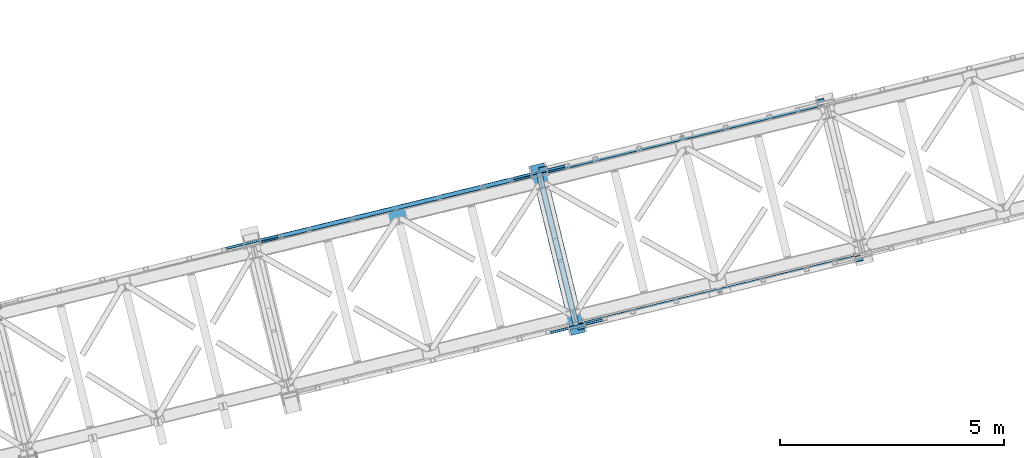
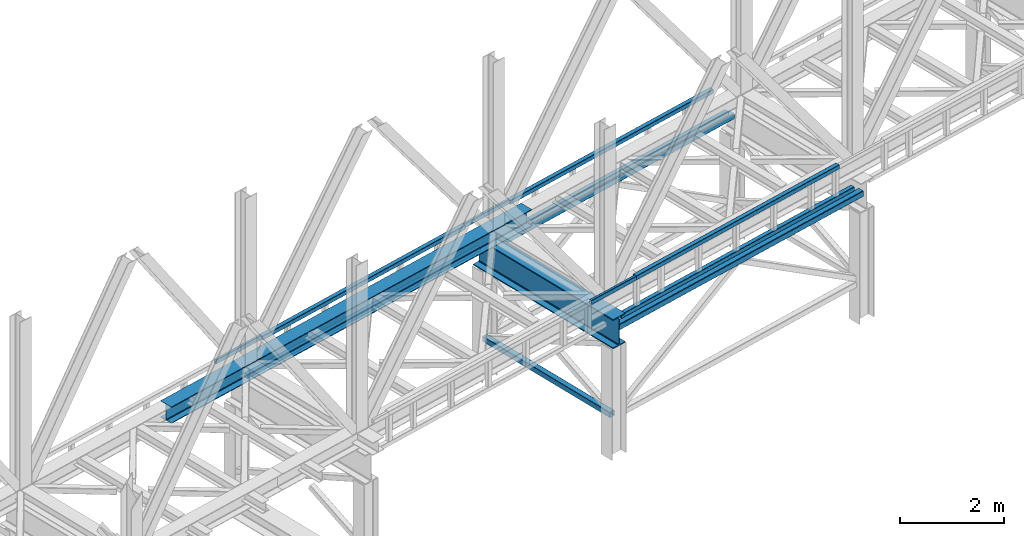
# One storey, part 16 of 92: 11 beams, 3 members.
"""IFC4 building model written with IfcOpenShell, lengths in millimetres."""

from ifc_helpers import new_model, entity, si_unit, converted_unit, derived_unit, direction, frame, origin, place, context, subcontext, project, spatial, indexed_curve, outline, extrude, material, type_object, element, save


model = new_model("IFC4")

# Units and contexts
model_context = context("Model", 3, precision=0.01, world=origin(), true_north=direction((6.12303176911189e-17, 1.0)))
plan_context = context("Plan", 3, precision=0.01, world=origin(), true_north=direction((6.12303176911189e-17, 1.0)))
body_context = subcontext(model_context, "Body", "Model", "MODEL_VIEW")
ifc_project = project(units=[si_unit("LENGTHUNIT", "METRE", prefix="MILLI"), si_unit("AREAUNIT", "SQUARE_METRE"), si_unit("VOLUMEUNIT", "CUBIC_METRE"), converted_unit("PLANEANGLEUNIT", "DEGREE", entity("IfcRatioMeasure", 0.0174532925199433), si_unit("PLANEANGLEUNIT", "RADIAN"), dimensions=[0, 0, 0, 0, 0, 0, 0]), si_unit("MASSUNIT", "GRAM", prefix="KILO"), derived_unit("MASSDENSITYUNIT", [(si_unit("MASSUNIT", "GRAM", prefix="KILO"), 1), (si_unit("LENGTHUNIT", "METRE"), -3)]), derived_unit("MOMENTOFINERTIAUNIT", [(si_unit("LENGTHUNIT", "METRE"), 4)]), si_unit("TIMEUNIT", "SECOND"), si_unit("FREQUENCYUNIT", "HERTZ"), si_unit("THERMODYNAMICTEMPERATUREUNIT", "DEGREE_CELSIUS"), derived_unit("THERMALTRANSMITTANCEUNIT", [(si_unit("MASSUNIT", "GRAM", prefix="KILO"), 1), (si_unit("THERMODYNAMICTEMPERATUREUNIT", "KELVIN"), -1), (si_unit("TIMEUNIT", "SECOND"), -3)]), derived_unit("VOLUMETRICFLOWRATEUNIT", [(si_unit("LENGTHUNIT", "METRE"), 3), (si_unit("TIMEUNIT", "SECOND"), -1)]), derived_unit("MASSFLOWRATEUNIT", [(si_unit("MASSUNIT", "GRAM", prefix="KILO"), 1), (si_unit("TIMEUNIT", "SECOND"), -1)]), derived_unit("ROTATIONALFREQUENCYUNIT", [(si_unit("TIMEUNIT", "SECOND"), -1)]), si_unit("ELECTRICCURRENTUNIT", "AMPERE"), si_unit("ELECTRICVOLTAGEUNIT", "VOLT"), si_unit("POWERUNIT", "WATT"), si_unit("FORCEUNIT", "NEWTON", prefix="KILO"), si_unit("ILLUMINANCEUNIT", "LUX"), si_unit("LUMINOUSFLUXUNIT", "LUMEN"), si_unit("LUMINOUSINTENSITYUNIT", "CANDELA"), derived_unit("USERDEFINED", [(si_unit("MASSUNIT", "GRAM", prefix="KILO"), -1), (si_unit("LENGTHUNIT", "METRE"), -2), (si_unit("TIMEUNIT", "SECOND"), 3), (si_unit("LUMINOUSFLUXUNIT", "LUMEN"), 1)]), derived_unit("LINEARVELOCITYUNIT", [(si_unit("LENGTHUNIT", "METRE"), 1), (si_unit("TIMEUNIT", "SECOND"), -1)]), si_unit("PRESSUREUNIT", "PASCAL"), derived_unit("USERDEFINED", [(si_unit("LENGTHUNIT", "METRE"), -2), (si_unit("MASSUNIT", "GRAM", prefix="KILO"), 1), (si_unit("TIMEUNIT", "SECOND"), -2)]), derived_unit("LINEARFORCEUNIT", [(si_unit("MASSUNIT", "GRAM", prefix="KILO"), 1), (si_unit("LENGTHUNIT", "METRE"), 1), (si_unit("TIMEUNIT", "SECOND"), -2), (si_unit("LENGTHUNIT", "METRE"), -1)]), derived_unit("PLANARFORCEUNIT", [(si_unit("MASSUNIT", "GRAM", prefix="KILO"), 1), (si_unit("LENGTHUNIT", "METRE"), 1), (si_unit("TIMEUNIT", "SECOND"), -2), (si_unit("LENGTHUNIT", "METRE"), -2)])], contexts=[model_context, plan_context])

# Site, building, storey
site_placement = place(None, origin())
site = spatial("IfcSite", under=ifc_project, at=site_placement, CompositionType="ELEMENT")
building_placement = place(site_placement, origin())
building = spatial("IfcBuilding", under=site, at=building_placement, CompositionType="ELEMENT")
storey_placement = place(building_placement, frame((0.0, 0.0, 15900.0)))
storey = spatial("IfcBuildingStorey", under=building, at=storey_placement, Name="05", CompositionType="ELEMENT", Elevation=15900.0)

# Beams
ifc_material = material(Name="Metal painted (White)")
beam_type = type_object("IfcBeamType", PredefinedType="BEAM")
placement = place(storey_placement, origin())
element("IfcBeam", 1, at=placement, inside=storey, type_object=beam_type, material=ifc_material, ObjectType="Steel Beam", PredefinedType="BEAM", context=body_context, shape_type="SweptSolid", body=[
    extrude(outline(indexed_curve([(-345.500000000002, -159.999999999984), (-322.5, -159.999999999984), (-322.5, -37.4999999999816), (-320.216385975338, -26.0194970290252), (-313.713203435595, -16.2867965643877), (-303.980502970953, -9.78361402464055), (-292.499999999998, -7.49999999997847), (292.500000000001, -7.49999999997847), (303.980502970953, -9.78361402464055), (313.713203435597, -16.2867965643877), (320.21638597534, -26.0194970290252), (322.5, -37.4999999999816), (322.5, -159.999999999984), (345.499999999997, -159.999999999984), (345.499999999997, 160.00000000002), (322.5, 160.00000000002), (322.5, 37.5000000000174), (320.21638597534, 26.0194970290696), (313.713203435597, 16.2867965644235), (303.980502970953, 9.78361402467601), (292.500000000001, 7.50000000002312), (-292.499999999998, 7.50000000002312), (-303.980502970953, 9.78361402468494), (-313.713203435595, 16.2867965644235), (-320.216385975338, 26.0194970290607), (-322.5, 37.5000000000174), (-322.5, 160.000000000019), (-345.500000000002, 160.00000000002), (-345.500000000002, -159.999999999984)], self_intersect=False)), frame((-42110.05, 6925.1, 2947.5), z_axis=(-0.236826092990338, 0.971552058141473, 0.0), x_axis=(0.0, 0.0, 1.0)), (0.0, 0.0, 1.0), 3899.99999999999),
])
element("IfcBeam", 2, at=placement, inside=storey, type_object=beam_type, material=ifc_material, ObjectType="Steel Beam", PredefinedType="BEAM", context=body_context, shape_type="SweptSolid", body=[
    extrude(outline(indexed_curve([(-195.999999999999, -150.000000000006), (-179.999999999996, -150.000000000006), (-179.999999999996, -27.7500000000052), (-178.325349715245, -19.3309644879713), (-173.556349186101, -12.1936508139007), (-166.419035512029, -7.42465028475701), (-157.999999999997, -5.75000000000425), (158.000000000005, -5.75000000000425), (166.419035512033, -7.42465028475701), (173.556349186107, -12.1936508139007), (178.325349715251, -19.3309644879713), (180.0, -27.7500000000052), (180.0, -150.000000000006), (196.000000000005, -150.000000000006), (196.000000000005, 149.999999999997), (180.0, 149.999999999997), (180.0, 27.7499999999967), (178.325349715251, 19.3309644879618), (173.556349186107, 12.1936508138912), (166.419035512033, 7.4246502847486), (158.000000000005, 5.74999999999479), (-157.999999999997, 5.74999999999584), (-166.419035512029, 7.42465028474754), (-173.556349186101, 12.1936508138923), (-178.325349715247, 19.3309644879639), (-179.999999999996, 27.7499999999988), (-179.999999999996, 149.999999999998), (-195.999999999999, 149.999999999997), (-195.999999999999, -150.000000000006)], self_intersect=False)), frame((-51415.73, 8259.22, 3489.0), z_axis=(0.971552058141477, 0.23682609299032, 0.0), x_axis=(0.0, 0.0, 1.0)), (0.0, 0.0, 1.0), 9600.0),
])
element("IfcBeam", 3, at=placement, inside=storey, type_object=beam_type, material=ifc_material, ObjectType="Steel Beam", PredefinedType="BEAM", context=body_context, shape_type="SweptSolid", body=[
    extrude(outline(indexed_curve([(29.4768951153018, -56.8428769008144), (33.3787015556258, -56.8428769008144), (36.9835006656596, -55.3497202198119), (39.7424944584905, -52.590726426981), (41.2356511394979, -48.9859273169476), (56.842876900814, 29.4768951153048), (56.8428769008189, 33.3787015556257), (55.3497202198128, 36.9835006656636), (52.590726426984, 39.7424944584929), (48.9859273169497, 41.2356511395006), (-29.4768951153031, 56.8428769008191), (-33.3787015556266, 56.8428769008212), (-36.9835006656618, 55.3497202198168), (-39.7424944584927, 52.5907264269859), (-41.2356511395002, 48.9859273169525), (-56.8428769008193, -29.4768951152993), (-56.8428769008191, -33.3787015556212), (-55.3497202198151, -36.9835006656587), (-52.5907264269859, -39.742494458486), (-48.985927316952, -41.2356511394957), (29.4768951153018, -56.8428769008144)], self_intersect=False), holes=[indexed_curve([(-50.9634988887179, -25.5484203233677), (-37.3071763475653, 43.1065493048552), (-35.8140196665578, 46.7113484148885), (-33.0550258737248, 49.470342207719), (-29.4502267636906, 50.9634988887236), (-25.5484203233682, 50.9634988887217), (43.1065493048514, 37.3071763475684), (46.7113484148898, 35.8140196665599), (49.4703422077155, 33.0550258737312), (50.9634988887226, 29.450226763693), (50.9634988887228, 25.5484203233711), (37.3071763475682, -43.1065493048513), (35.8140196665566, -46.7113484148839), (33.0550258737271, -49.4703422077128), (29.4502267636909, -50.963498888717), (25.5484203233684, -50.9634988887151), (-43.1065493048507, -37.3071763475597), (-46.711348414886, -35.8140196665518), (-49.4703422077108, -33.0550258737233), (-50.9634988887187, -29.4502267636894), (-50.9634988887179, -25.5484203233677)], self_intersect=False)]), frame((-49204.23, 9004.15, 3118.0), z_axis=(0.971552058141251, 0.23682609299125, 0.0), x_axis=(-0.232275546020868, 0.952883957770417, 0.195090322016481)), (0.0, 0.0, 1.0), 6199.99999999998),
])
element("IfcBeam", 4, at=placement, inside=storey, type_object=beam_type, material=ifc_material, ObjectType="Steel Beam", PredefinedType="BEAM", context=body_context, shape_type="SweptSolid", body=[
    extrude(outline(indexed_curve([(29.4768951153029, -56.8428769008146), (33.3787015556268, -56.8428769008146), (36.9835006656606, -55.3497202198121), (39.7424944584956, -52.590726426982), (41.235651139502, -48.9859273169485), (56.8428769008191, 29.4768951153038), (56.842876900822, 33.378701555625), (55.3497202198149, 36.9835006656632), (52.5907264269871, 39.7424944584923), (48.9859273169518, 41.2356511395002), (-29.4768951153, 56.8428769008184), (-33.3787015556235, 56.8428769008206), (-36.9835006656577, 55.349720219816), (-39.7424944584866, 52.5907264269846), (-41.2356511394971, 48.9859273169519), (-56.8428769008121, -29.4768951153007), (-56.8428769008149, -33.378701555622), (-55.349720219812, -36.9835006656594), (-52.5907264269838, -39.7424944584864), (-48.9859273169489, -41.2356511394963), (29.4768951153029, -56.8428769008146)], self_intersect=False), holes=[indexed_curve([(-50.9634988887168, -25.5484203233679), (-37.3071763475642, 43.106549304855), (-35.8140196665578, 46.7113484148885), (-33.0550258737248, 49.470342207719), (-29.4502267636906, 50.9634988887236), (-25.5484203233671, 50.9634988887215), (43.1065493048524, 37.3071763475682), (46.7113484148898, 35.8140196665599), (49.4703422077155, 33.0550258737312), (50.9634988887247, 29.4502267636926), (50.9634988887239, 25.5484203233709), (37.3071763475671, -43.1065493048511), (35.8140196665587, -46.7113484148843), (33.0550258737282, -49.4703422077131), (29.4502267636919, -50.9634988887172), (25.5484203233684, -50.9634988887151), (-43.1065493048507, -37.3071763475597), (-46.7113484148819, -35.8140196665527), (-49.4703422077097, -33.0550258737235), (-50.9634988887176, -29.4502267636896), (-50.9634988887168, -25.5484203233679)], self_intersect=False)]), frame((-42791.99, 10567.2, 3118.0), z_axis=(0.971552058141251, 0.23682609299125, 0.0), x_axis=(-0.232275546020868, 0.952883957770417, 0.195090322016481)), (0.0, 0.0, 1.0), 6200.00000000001),
])
element("IfcBeam", 5, at=placement, inside=storey, type_object=beam_type, material=ifc_material, ObjectType="Steel Beam", PredefinedType="BEAM", context=body_context, shape_type="SweptSolid", body=[
    extrude(outline(indexed_curve([(29.4768951153347, -56.8428769007943), (33.3787015556582, -56.8428769007943), (36.9835006656916, -55.3497202197878), (39.7424944585226, -52.5907264269579), (41.2356511395291, -48.9859273169239), (56.8428769008035, 29.4768951153368), (56.8428769008039, 33.378701555667), (55.3497202197956, 36.9835006656975), (52.5907264269664, 39.7424944585252), (48.985927316931, 41.2356511395353), (-29.4768951153292, 56.8428769008109), (-33.3787015556536, 56.8428769008067), (-36.983500665687, 55.3497202198001), (-39.7424944585192, 52.5907264269749), (-41.2356511395254, 48.985927316932), (-56.8428769007998, -29.4768951153287), (-56.8428769008005, -33.37870155565), (-55.349720219791, -36.9835006656852), (-52.5907264269618, -39.7424944585128), (-48.9859273169256, -41.2356511395187), (29.4768951153347, -56.8428769007943)], self_intersect=False), holes=[indexed_curve([(-50.9634988887049, -25.5484203233842), (-37.3071763475873, 43.1065493048368), (-35.8140196665807, 46.7113484148708), (-33.0550258737509, 49.4703422077053), (-29.4502267637155, 50.9634988887115), (-25.548420323394, 50.9634988887119), (43.106549304835, 37.3071763475954), (46.7113484148691, 35.81401966659), (49.4703422076963, 33.0550258737628), (50.9634988887049, 29.4502267637233), (50.9634988887063, 25.5484203234016), (37.3071763475907, -43.1065493048198), (35.8140196665866, -46.7113484148631), (33.0550258737555, -49.470342207693), (29.4502267637221, -50.9634988886995), (25.5484203233986, -50.9634988886995), (-43.1065493048304, -37.3071763475831), (-46.7113484148624, -35.814019666578), (-49.4703422076938, -33.05502587375), (-50.9634988887032, -29.4502267637148), (-50.9634988887049, -25.5484203233842)], self_intersect=False)]), frame((-42403.37, 10661.93, 3830.0), z_axis=(0.971552058141251, 0.23682609299125, 0.0), x_axis=(0.232275546020893, -0.95288395777052, -0.195090322015947)), (0.0, 0.0, 1.0), 5399.99999999998),
])
element("IfcBeam", 6, at=placement, inside=storey, type_object=beam_type, material=ifc_material, ObjectType="Steel Beam", PredefinedType="BEAM", context=body_context, shape_type="SweptSolid", body=[
    extrude(outline(indexed_curve([(29.4768951153316, -56.8428769007937), (33.3787015556551, -56.8428769007937), (36.9835006656885, -55.3497202197871), (39.7424944585144, -52.5907264269562), (41.2356511395209, -48.9859273169223), (56.8428769007963, 29.4768951153382), (56.8428769007977, 33.3787015556682), (55.3497202197915, 36.9835006656984), (52.5907264269612, 39.7424944585262), (48.9859273169269, 41.2356511395361), (-29.4768951153344, 56.8428769008119), (-33.3787015556587, 56.8428769008077), (-36.9835006656932, 55.3497202198013), (-39.7424944585223, 52.5907264269755), (-41.2356511395285, 48.9859273169326), (-56.8428769008049, -29.4768951153277), (-56.8428769008046, -33.3787015556492), (-55.3497202197962, -36.9835006656842), (-52.5907264269659, -39.742494458512), (-48.9859273169297, -41.2356511395179), (29.4768951153316, -56.8428769007937)], self_intersect=False), holes=[indexed_curve([(-50.963498888708, -25.5484203233836), (-37.3071763475914, 43.1065493048376), (-35.8140196665838, 46.7113484148714), (-33.055025873754, 49.4703422077059), (-29.4502267637186, 50.9634988887121), (-25.5484203233971, 50.9634988887125), (43.1065493048299, 37.3071763475965), (46.7113484148619, 35.8140196665914), (49.4703422076901, 33.055025873764), (50.9634988887039, 29.4502267637235), (50.9634988887052, 25.5484203234018), (37.3071763475896, -43.1065493048196), (35.8140196665804, -46.7113484148619), (33.0550258737504, -49.4703422076919), (29.450226763718, -50.9634988886987), (25.5484203233955, -50.9634988886989), (-43.1065493048325, -37.3071763475827), (-46.7113484148696, -35.8140196665766), (-49.470342207701, -33.0550258737486), (-50.9634988887063, -29.4502267637142), (-50.963498888708, -25.5484203233836)], self_intersect=False)]), frame((-48815.61, 9098.88, 3830.0), z_axis=(0.971552058141251, 0.23682609299125, 0.0), x_axis=(0.232275546020893, -0.95288395777052, -0.195090322015947)), (0.0, 0.0, 1.0), 5400.00000000001),
])
element("IfcBeam", 7, at=placement, inside=storey, type_object=beam_type, material=ifc_material, ObjectType="Steel Beam", PredefinedType="BEAM", context=body_context, shape_type="SweptSolid", body=[
    extrude(outline(indexed_curve([(9.86118950715225, -52.9410704605097), (13.7629959474774, -52.9410704605097), (17.3677950575143, -51.4479137795155), (20.1267888503502, -48.6889199866869), (21.6199455313614, -45.0841208766556), (37.2271712928088, 33.3787015555707), (37.227171292818, 37.280507995892), (35.7340146118185, 40.8853071059301), (32.9750208189942, 43.6443008987639), (29.3702217089621, 45.1374575797819), (-9.86118950715206, 52.9410704605053), (-13.7629959474754, 52.9410704605093), (-17.367795057512, 51.4479137795106), (-20.1267888503471, 48.6889199866863), (-21.6199455313584, 45.084120876655), (-37.2271712928057, -33.3787015555713), (-37.2271712928159, -37.2805079958924), (-35.7340146118152, -40.8853071059351), (-32.9750208189911, -43.6443008987645), (-29.3702217089609, -45.1374575797865), (9.86118950715225, -52.9410704605097)], self_intersect=False), holes=[indexed_curve([(-31.347793280702, -29.4502267636485), (-17.6914707394371, 39.204742864552), (-16.1983140584197, 42.8095419745821), (-13.4393202655878, 45.568535767407), (-9.834521155548, 47.0616924484051), (-5.93271471522451, 47.0616924483966), (23.4908436968575, 41.2089827878548), (27.0956428068904, 39.7158261068411), (29.8546365997147, 36.9568323140073), (31.3477932807163, 33.3520332039688), (31.3477932807071, 29.4502267636475), (17.6914707394423, -39.2047428645531), (16.1983140584279, -42.8095419745838), (13.43932026559, -45.5685357674119), (9.8345211555542, -47.0616924484064), (5.93271471523173, -47.0616924483981), (-23.4908436968513, -41.208982787856), (-27.0956428068832, -39.7158261068425), (-29.8546365997085, -36.9568323140085), (-31.3477932807081, -33.3520332039704), (-31.347793280702, -29.4502267636485)], self_intersect=False)]), frame((-49986.21, 8834.12, 3830.0), z_axis=(0.971552058141243, 0.236826092991282, 0.0), x_axis=(-0.232275546020792, 0.952883957770107, 0.195090322018083)), (0.0, 0.0, 1.0), 1200.0),
])
element("IfcBeam", 8, at=placement, inside=storey, type_object=beam_type, material=ifc_material, ObjectType="Steel Beam", PredefinedType="BEAM", context=body_context, shape_type="SweptSolid", body=[
    extrude(outline(indexed_curve([(9.86118950715024, -52.9410704605093), (13.7629959474754, -52.9410704605093), (17.3677950575112, -51.4479137795149), (20.1267888503492, -48.6889199866867), (21.6199455313614, -45.0841208766556), (37.2271712928046, 33.3787015555715), (37.227171292818, 37.280507995892), (35.7340146118163, 40.8853071059305), (32.9750208189931, 43.6443008987641), (29.370221708961, 45.1374575797821), (-9.86118950715314, 52.9410704605055), (-13.7629959474754, 52.9410704605093), (-17.3677950575141, 51.447913779511), (-20.1267888503492, 48.6889199866867), (-21.6199455313635, 45.084120876656), (-37.2271712928087, -33.3787015555707), (-37.227171292818, -37.280507995892), (-35.7340146118193, -40.8853071059343), (-32.9750208189931, -43.6443008987641), (-29.3702217089639, -45.1374575797859), (9.86118950715024, -52.9410704605093)], self_intersect=False), holes=[indexed_curve([(-31.3477932807029, -29.4502267636483), (-17.6914707394361, 39.2047428645519), (-16.1983140584218, 42.8095419745826), (-13.4393202655909, 45.5685357674077), (-9.83452115555012, 47.0616924484056), (-5.93271471522662, 47.0616924483971), (23.4908436968565, 41.208982787855), (27.0956428068852, 39.7158261068421), (29.8546365997126, 36.9568323140076), (31.3477932807142, 33.3520332039692), (31.3477932807071, 29.4502267636475), (17.6914707394403, -39.2047428645527), (16.1983140584259, -42.8095419745834), (13.439320265588, -45.5685357674115), (9.83452115555012, -47.0616924484056), (5.93271471523075, -47.0616924483979), (-23.4908436968565, -41.208982787855), (-27.0956428068832, -39.7158261068425), (-29.8546365997085, -36.9568323140085), (-31.3477932807101, -33.35203320397), (-31.3477932807029, -29.4502267636483)], self_intersect=False)]), frame((-43573.97, 10397.17, 3830.0), z_axis=(0.971552058141251, 0.23682609299125, 0.0), x_axis=(-0.232275546020792, 0.952883957770107, 0.195090322018083)), (0.0, 0.0, 1.0), 1199.99999999999),
])
element("IfcBeam", 9, at=placement, inside=storey, type_object=beam_type, material=ifc_material, ObjectType="Steel Beam", PredefinedType="BEAM", context=body_context, shape_type="SweptSolid", body=[
    extrude(outline(indexed_curve([(29.4768951153303, -56.8428769008022), (33.3787015556528, -56.8428769008022), (36.9835006656877, -55.3497202197939), (39.7424944585154, -52.5907264269657), (41.2356511395221, -48.9859273169318), (56.8428769008018, 29.4768951153279), (56.8428769008011, 33.3787015556517), (55.3497202197953, 36.9835006656885), (52.5907264269647, 39.7424944585144), (48.9859273169307, 41.23565113952), (-29.4768951153307, 56.8428769008001), (-33.3787015556532, 56.8428769008001), (-36.9835006656873, 55.349720219796), (-39.7424944585158, 52.5907264269635), (-41.2356511395229, 48.9859273169275), (-56.8428769008026, -29.4768951153321), (-56.8428769008015, -33.3787015556538), (-55.3497202197949, -36.9835006656864), (-52.5907264269652, -39.7424944585165), (-48.9859273169312, -41.2356511395222), (29.4768951153303, -56.8428769008022)], self_intersect=False), holes=[indexed_curve([(-50.9634988887073, -25.5484203233968), (-37.3071763475893, 43.1065493048329), (-35.8140196665836, 46.711348414867), (-33.055025873752, 49.4703422076989), (-29.450226763717, 50.9634988887072), (-25.5484203233935, 50.963498888707), (43.1065493048327, 37.3071763475875), (46.7113484148708, 35.814019666581), (49.4703422077005, 33.0550258737509), (50.9634988887053, 29.4502267637143), (50.9634988887054, 25.5484203233928), (37.3071763475853, -43.1065493048366), (35.8140196665786, -46.7113484148704), (33.0550258737495, -49.4703422077006), (29.4502267637154, -50.9634988887046), (25.5484203233919, -50.9634988887045), (-43.1065493048333, -37.3071763475851), (-46.7113484148703, -35.8140196665789), (-49.4703422076995, -33.0550258737511), (-50.9634988887071, -29.4502267637183), (-50.9634988887073, -25.5484203233968)], self_intersect=False)]), frame((-41960.97, 7158.03, 3118.0), z_axis=(0.97155205814122, 0.236826092991375, 0.0), x_axis=(-0.232275546020954, 0.952883957770495, 0.195090322015999)), (0.0, 0.0, 1.0), 6200.00000000002),
])
element("IfcBeam", 10, at=placement, inside=storey, type_object=beam_type, material=ifc_material, ObjectType="Steel Beam", PredefinedType="BEAM", context=body_context, shape_type="SweptSolid", body=[
    extrude(outline(indexed_curve([(29.4768951153305, -56.8428769007956), (33.378701555653, -56.8428769007956), (36.9835006656875, -55.3497202197894), (39.7424944585167, -52.5907264269593), (41.2356511395223, -48.9859273169252), (56.842876900802, 29.4768951153345), (56.8428769008026, 33.3787015556647), (55.3497202197956, 36.9835006656951), (52.5907264269654, 39.7424944585231), (48.9859273169322, 41.235651139533), (-29.4768951153282, 56.8428769008128), (-33.3787015556525, 56.8428769008088), (-36.9835006656871, 55.3497202198026), (-39.7424944585143, 52.5907264269765), (-41.2356511395227, 48.9859273169341), (-56.8428769008024, -29.4768951153256), (-56.8428769008013, -33.3787015556473), (-55.3497202197951, -36.9835006656819), (-52.5907264269649, -39.7424944585099), (-48.9859273169299, -41.2356511395158), (29.4768951153305, -56.8428769007956)], self_intersect=False), holes=[indexed_curve([(-50.9634988887053, -25.5484203233818), (-37.3071763475859, 43.1065493048389), (-35.8140196665772, 46.7113484148724), (-33.0550258737482, 49.470342207707), (-29.4502267637158, 50.9634988887136), (-25.5484203233933, 50.9634988887136), (43.1065493048319, 37.3071763475942), (46.71134841487, 35.8140196665878), (49.470342207696, 33.0550258737606), (50.9634988887045, 29.4502267637211), (50.9634988887056, 25.5484203233994), (37.3071763475893, -43.1065493048219), (35.8140196665799, -46.7113484148641), (33.0550258737508, -49.4703422076942), (29.4502267637152, -50.9634988887002), (25.5484203233927, -50.9634988887002), (-43.1065493048345, -37.3071763475805), (-46.7113484148685, -35.8140196665748), (-49.4703422076976, -33.055025873747), (-50.9634988887048, -29.4502267637122), (-50.9634988887053, -25.5484203233818)], self_intersect=False)]), frame((-41572.35, 7252.76, 3830.0), z_axis=(0.97155205814122, 0.236826092991375, 0.0), x_axis=(0.232275546020954, -0.952883957770495, -0.195090322015999)), (0.0, 0.0, 1.0), 5399.99999999998),
])
element("IfcBeam", 11, at=placement, inside=storey, type_object=beam_type, material=ifc_material, ObjectType="Steel Beam", PredefinedType="BEAM", context=body_context, shape_type="SweptSolid", body=[
    extrude(outline(indexed_curve([(9.86118950714837, -52.94107046051), (13.7629959474725, -52.94107046051), (17.3677950575095, -51.447913779516), (20.1267888503455, -48.6889199866876), (21.619945531358, -45.0841208766565), (37.2271712928105, 33.3787015555687), (37.2271712928189, 37.2805079958902), (35.7340146118196, 40.8853071059284), (32.9750208189954, 43.6443008987624), (29.3702217089645, 45.1374575797803), (-9.86118950714922, 52.9410704605058), (-13.7629959474725, 52.94107046051), (-17.3677950575103, 51.4479137795117), (-20.1267888503455, 48.6889199866876), (-21.619945531358, 45.0841208766565), (-37.2271712928105, -33.3787015555687), (-37.2271712928189, -37.2805079958902), (-35.7340146118204, -40.8853071059326), (-32.9750208189954, -43.6443008987624), (-29.3702217089653, -45.1374575797846), (9.86118950714837, -52.94107046051)], self_intersect=False), holes=[indexed_curve([(-31.3477932807035, -29.4502267636469), (-17.691470739433, 39.2047428645526), (-16.1983140584174, 42.809541974583), (-13.4393202655874, 45.5685357674081), (-9.83452115554754, 47.0616924484061), (-5.93271471522507, 47.0616924483976), (23.4908436968607, 41.2089827878534), (27.0956428068884, 39.7158261068405), (29.8546365997146, 36.9568323140061), (31.347793280715, 33.3520332039677), (31.3477932807076, 29.450226763646), (17.6914707394371, -39.2047428645534), (16.1983140584215, -42.8095419745838), (13.4393202655865, -45.5685357674124), (9.8345211555496, -47.0616924484065), (5.93271471522817, -47.0616924483982), (-23.4908436968576, -41.208982787854), (-27.0956428068853, -39.7158261068411), (-29.8546365997082, -36.9568323140118), (-31.3477932807109, -33.3520332039686), (-31.3477932807035, -29.4502267636469)], self_intersect=False)]), frame((-42733.47, 6949.14, 3830.0), z_axis=(0.97155205814122, 0.236826092991375, 0.0), x_axis=(-0.232275546020854, 0.952883957770082, 0.195090322018134)), (0.0, 0.0, 1.0), 1199.99999999999),
])

# Members
member_type_1 = type_object("IfcMemberType", PredefinedType="BRACE")
element("IfcMember", 12, at=placement, inside=storey, type_object=member_type_1, ObjectType="Steel Vertical Brace", PredefinedType="BRACE", context=body_context, shape_type="SweptSolid", body=[
    extrude(outline(indexed_curve([(41.2596526560579, -71.9315025750194), (44.3810978083225, -71.9315025750194), (47.2649370963498, -70.7369772302093), (49.4721321306099, -68.5297821959409), (50.6666574754114, -65.6459429079105), (71.9315025750208, 41.2596526560702), (71.9315025750162, 44.3810978083293), (70.7369772302065, 47.2649370963526), (68.5297821959393, 49.4721321306162), (65.6459429079025, 50.6666574754182), (-41.2596526560747, 71.931502575025), (-44.3810978083313, 71.9315025750212), (-47.264937096359, 70.7369772302089), (-49.4721321306182, 68.5297821959448), (-50.6666574754197, 65.6459429079143), (-71.9315025750291, -41.2596526560663), (-71.9315025750246, -44.3810978083254), (-70.7369772302157, -47.264937096353), (-68.529782195948, -49.4721321306145), (-65.6459429079195, -50.6666574754126), (41.2596526560579, -71.9315025750194)], self_intersect=False), holes=[indexed_curve([(-67.228000165357, -38.1168728225121), (-47.5238776418647, 60.9424404982423), (-46.3293522970628, 63.8262797862748), (-44.1221572628033, 66.0334748205389), (-41.2383179747765, 67.2280001653469), (-38.1168728225197, 67.2280001653529), (60.9424404982391, 47.5238776418622), (63.8262797862667, 46.3293522970598), (66.0334748205344, 44.1221572627983), (67.2280001653441, 41.238317974775), (67.2280001653487, 38.1168728225159), (47.5238776418564, -60.9424404982384), (46.3293522970461, -63.8262797862671), (44.122157262786, -66.0334748205354), (41.2383179747684, -67.2280001653431), (38.1168728225029, -67.2280001653473), (-60.9424404982471, -47.5238776418584), (-63.826279786275, -46.329352297056), (-66.0334748205436, -44.1221572627987), (-67.2280001653524, -41.2383179747711), (-67.228000165357, -38.1168728225121)], self_intersect=False)]), frame((-42157.04, 7117.9, 898.0), z_axis=(-0.236826092990098, 0.971552058141532, 0.0), x_axis=(-0.952883957770956, -0.232275546020111, 0.195090322014749)), (0.0, 0.0, 1.0), 3545.80325659093),
])
member_type_2 = type_object("IfcMemberType", PredefinedType="BRACE")
element("IfcMember", 13, at=placement, inside=storey, type_object=member_type_2, ObjectType="Steel Vertical Brace", PredefinedType="BRACE", context=body_context, shape_type="SweptSolid", body=[
    extrude(outline(indexed_curve([(37.8349046800508, -78.8972115340725), (44.6630659506159, -78.8972115340725), (50.971464393175, -76.2841873423058), (55.7997035306284, -71.4559482048567), (58.4127277223887, -65.1475497622927), (78.897211534066, 37.8349046800475), (78.8972115340659, 44.66306595061), (76.2841873423012, 50.9714643931725), (71.4559482048499, 55.7997035306222), (65.1475497622896, 58.4127277223865), (-37.8349046800525, 78.897211534064), (-44.6630659506184, 78.8972115340597), (-50.9714643931777, 76.2841873422975), (-55.7997035306309, 71.455948204844), (-58.4127277223904, 65.1475497622842), (-78.8972115340677, -37.834904680056), (-78.8972115340684, -44.6630659506228), (-76.284187342304, -50.9714643931808), (-71.4559482048524, -55.7997035306349), (-65.1475497622912, -58.412727722395), (37.8349046800508, -78.8972115340725)], self_intersect=False), holes=[indexed_curve([(-56.9164205453576, -52.9128630136832), (-63.2248189879183, -50.299838821921), (-68.0530581253707, -45.4715996844711), (-70.6660823171321, -39.1632012419137), (-70.6660823171344, -32.3350399713463), (-52.9128630136808, 56.9164205453492), (-50.2998388219219, 63.2248189879113), (-45.4715996844677, 68.0530581253646), (-39.1632012419078, 70.6660823171245), (-32.3350399713429, 70.666082317129), (56.9164205453538, 52.9128630136751), (63.2248189879131, 50.299838821911), (68.053058125369, 45.4715996844626), (70.6660823171295, 39.163201241901), (70.6660823171313, 32.3350399713359), (52.9128630136777, -56.9164205453596), (50.2998388219142, -63.224818987923), (45.4715996844625, -68.0530581253746), (39.1632012419036, -70.6660823171348), (32.3350399713391, -70.6660823171371), (-56.9164205453576, -52.9128630136832)], self_intersect=False)]), frame((-42128.57, 7074.97, 2948.01), z_axis=(0.971552058141313, 0.236826092990994, 0.0), x_axis=(-0.232275546020611, 0.952883957770583, 0.195090322015976)), (0.0, 0.0, 1.0), 6564.99999999999),
])
member_type_3 = type_object("IfcMemberType", PredefinedType="BRACE")
element("IfcMember", 14, at=placement, inside=storey, type_object=member_type_3, ObjectType="Steel Vertical Brace", PredefinedType="BRACE", context=body_context, shape_type="SweptSolid", body=[
    extrude(outline(indexed_curve([(37.8349046800522, -78.8972115340712), (44.6630659506184, -78.8972115340712), (50.9714643931763, -76.2841873423041), (55.7997035306285, -71.4559482048547), (58.4127277223887, -65.1475497622906), (78.8972115340617, 37.8349046800504), (78.8972115340614, 44.663065950613), (76.2841873422986, 50.971464393175), (71.4559482048471, 55.7997035306245), (65.1475497622867, 58.4127277223886), (-37.834904680056, 78.8972115340631), (-44.6630659506209, 78.8972115340584), (-50.9714643931801, 76.284187342296), (-55.7997035306331, 71.4559482048423), (-58.4127277223925, 65.1475497622825), (-78.8972115340675, -37.8349046800581), (-78.897211534066, -44.6630659506253), (-76.2841873423024, -50.9714643931831), (-71.4559482048517, -55.7997035306368), (-65.1475497622905, -58.4127277223967), (37.8349046800522, -78.8972115340712)], self_intersect=False), holes=[indexed_curve([(-56.916420545358, -52.9128630136845), (-63.2248189879188, -50.2998388219225), (-68.0530581253703, -45.471599684473), (-70.6660823171319, -39.1632012419157), (-70.6660823171375, -32.3350399713476), (-52.9128630136836, 56.9164205453479), (-50.299838821926, 63.2248189879102), (-45.4715996844729, 68.0530581253639), (-39.163201241912, 70.6660823171238), (-32.3350399713492, 70.6660823171289), (56.9164205453481, 52.9128630136776), (63.2248189879109, 50.2998388219152), (68.0530581253645, 45.4715996844653), (70.6660823171253, 39.1632012419037), (70.6660823171252, 32.335039971339), (52.9128630136794, -56.9164205453581), (50.2998388219131, -63.2248189879209), (45.4715996844666, -68.0530581253737), (39.1632012419038, -70.6660823171332), (32.3350399713372, -70.6660823171353), (-56.916420545358, -52.9128630136845)], self_intersect=False)]), frame((-42981.14, 10572.56, 2948.01), z_axis=(0.97155205814133, 0.236826092990923, 0.0), x_axis=(-0.232275546020575, 0.952883957770598, 0.195090322015947)), (0.0, 0.0, 1.0), 6564.99999999999),
])

save(model, "model.ifc")
